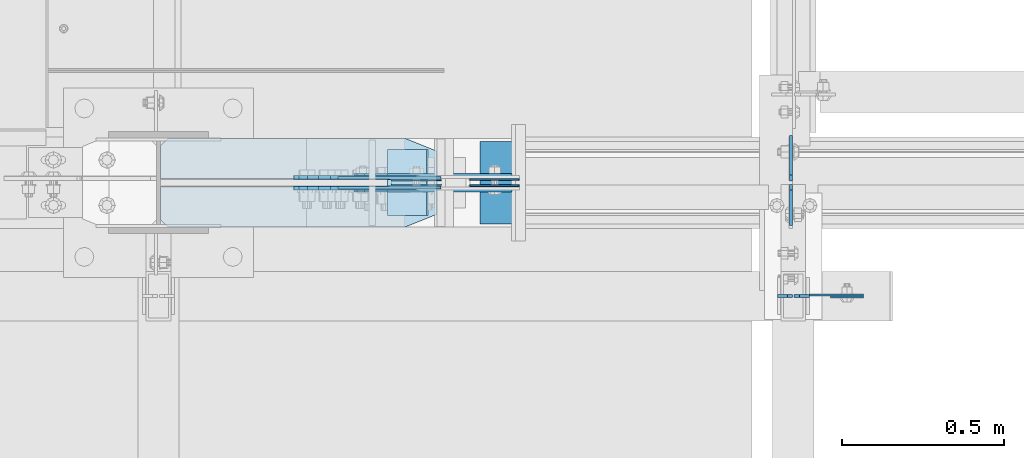
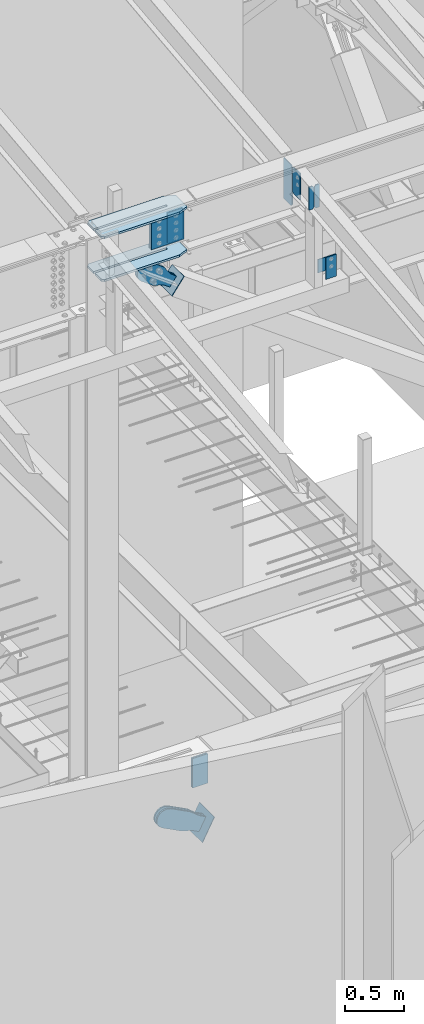
# One storey, part 998 of 1179: 20 plates, 14 elements without a shape of their own.
"""IFC2X3 building model written with IfcOpenShell, lengths in millimetres."""

from ifc_helpers import new_model, si_unit, frame, origin_with_axes, place, context, subcontext, project, spatial, faceted_brep, material, type_object, element, aggregate, save


model = new_model("IFC2X3")

# Units and contexts
model_context = context("Model", 3, precision=1e-05, world=origin_with_axes())
body_context = subcontext(model_context, "Body", "Model", "MODEL_VIEW")
ifc_project = project(units=[si_unit("LENGTHUNIT", "METRE", prefix="MILLI"), si_unit("AREAUNIT", "SQUARE_METRE"), si_unit("VOLUMEUNIT", "CUBIC_METRE"), si_unit("MASSUNIT", "GRAM", prefix="KILO"), si_unit("TIMEUNIT", "SECOND"), si_unit("PLANEANGLEUNIT", "RADIAN"), si_unit("SOLIDANGLEUNIT", "STERADIAN"), si_unit("THERMODYNAMICTEMPERATUREUNIT", "DEGREE_CELSIUS"), si_unit("LUMINOUSINTENSITYUNIT", "LUMEN")], contexts=[model_context])

# Site, building, storey
site_placement = place(None, origin_with_axes())
site = spatial("IfcSite", under=ifc_project, at=site_placement, CompositionType="ELEMENT")
building_placement = place(site_placement, origin_with_axes())
building = spatial("IfcBuilding", under=site, at=building_placement, Name="Undefined", CompositionType="ELEMENT")
storey_placement = place(building_placement, origin_with_axes())
storey = spatial("IfcBuildingStorey", under=building, at=storey_placement, Name="Undefined", CompositionType="ELEMENT", Elevation=0.0)

# Assembly, plate
assembly_1_placement = place(storey_placement, origin_with_axes())
assembly_1 = element("IfcElementAssembly", 1, at=assembly_1_placement, inside=storey, Name="BEAM", AssemblyPlace="NOTDEFINED", PredefinedType="RIGID_FRAME")
ifc_material_1 = material(Name="STEEL/A36")
plate_type_1 = type_object("IfcPlateType", PredefinedType="NOTDEFINED")
plate_1_placement = place(assembly_1_placement, frame((18407.8557500839, 5430.05308465637, 9531.6412842795), z_axis=(0.0, 0.0, 1.0), x_axis=(0.0, -1.0, 0.0)))
plate_1 = element("IfcPlate", 2, at=plate_1_placement, type_object=plate_type_1, material=ifc_material_1, Name="PLATE", context=body_context, shape_type="Brep", body=[
    faceted_brep([(-1.81898940354586e-12, -4.76249999999345, 17.4624996185303), (0.0, -4.76250000000073, 257.17500038147), (0.0, 4.76250000000073, 257.17500038147), (1.81898940354586e-12, 4.76250000000073, 17.4624996185303), (17.4624996185303, -4.76250000000073, 274.637500000001), (17.4624996185303, 4.76250000000073, 274.637500000001), (127.0, -4.76250000000073, 274.637500000001), (127.0, 4.76250000000073, 274.637500000001), (127.0, -4.76250000000073, 0.0), (127.0, 4.76250000000073, 0.0), (17.4624996185157, -4.76250000000073, 0.0), (17.4624996185212, 4.76249999999345, 0.0)], [[[0, 1, 2, 3]], [[1, 4, 5, 2]], [[4, 6, 7, 5]], [[6, 8, 9, 7]], [[8, 10, 11, 9]], [[10, 0, 3, 11]], [[5, 7, 9, 11, 3, 2]], [[10, 8, 6, 4, 1, 0]]]),
])

assembly_2_placement = place(storey_placement, origin_with_axes())
assembly_2 = element("IfcElementAssembly", 3, at=assembly_2_placement, inside=storey, Name="COLUMN", AssemblyPlace="NOTDEFINED", PredefinedType="RIGID_FRAME")
plate_type_2 = type_object("IfcPlateType", PredefinedType="NOTDEFINED")
plate_2_placement = place(assembly_2_placement, frame((18630.9, 5089.525, 9029.7), z_axis=(-1.0, 0.0, 0.0), x_axis=(0.0, 0.0, -1.0)))
plate_2 = element("IfcPlate", 4, at=plate_2_placement, type_object=plate_type_2, material=ifc_material_1, Name="PLATE", context=body_context, shape_type="Brep", body=[
    faceted_brep([(0.0, -3.17500000000109, 0.0), (0.0, -3.17500000000018, 177.800000000003), (0.0, 3.17500000000018, 177.800000000003), (0.0, 3.17500000000109, 7.27595761418343e-12), (139.699996948242, -3.17500000000018, 177.800000000003), (139.699996948242, 3.17500000000018, 177.800000000003), (139.699996948242, -3.17500000000018, 0.0), (139.699996948242, 3.17500000000018, 0.0)], [[[0, 1, 2, 3]], [[1, 4, 5, 2]], [[4, 6, 7, 5]], [[6, 0, 3, 7]], [[5, 7, 3, 2]], [[6, 4, 1, 0]]]),
])
aggregate(assembly_2, [plate_2])

assembly_3_placement = place(storey_placement, origin_with_axes())
assembly_3 = element("IfcElementAssembly", 5, at=assembly_3_placement, inside=storey, Name="BEAM", AssemblyPlace="NOTDEFINED", PredefinedType="RIGID_FRAME")
plate_type_3 = type_object("IfcPlateType", PredefinedType="NOTDEFINED")
plate_3_placement = place(assembly_3_placement, frame((18630.9, 5083.175, 9029.7), z_axis=(-1.0, 0.0, 0.0), x_axis=(0.0, 0.0, -1.0)))
plate_3 = element("IfcPlate", 6, at=plate_3_placement, type_object=plate_type_3, material=ifc_material_1, Name="PLATE", context=body_context, shape_type="Brep", body=[
    faceted_brep([(0.0, -3.17500000000109, 0.0), (0.0, -3.17500000000018, 101.599999999999), (0.0, 3.17500000000018, 101.599999999999), (0.0, 3.17500000000109, 7.27595761418343e-12), (228.6, -3.17500000000018, 101.600000000002), (228.6, 3.17500000000018, 101.600000000002), (228.6, -3.17500000000018, 0.0), (228.6, 3.17500000000018, 0.0)], [[[0, 1, 2, 3]], [[1, 4, 5, 2]], [[4, 6, 7, 5]], [[6, 0, 3, 7]], [[5, 7, 3, 2]], [[6, 4, 1, 0]]]),
])
aggregate(assembly_3, [plate_3])

# Assembly, plates
assembly_4_placement = place(storey_placement, origin_with_axes())
assembly_4 = element("IfcElementAssembly", 7, at=assembly_4_placement, inside=storey, Name="COLUMN", AssemblyPlace="NOTDEFINED", PredefinedType="RIGID_FRAME")
ifc_material_2 = material(Name="STEEL/A572-GR.50")
plate_type_4 = type_object("IfcPlateType", PredefinedType="NOTDEFINED")
plate_4_placement = place(assembly_4_placement, frame((17317.4400137532, 5298.77294084992, 9371.30378424801), z_axis=(0.0, 1.0, 0.0), x_axis=(-1.0, 0.0, 0.0)))
plate_4 = element("IfcPlate", 8, at=plate_4_placement, type_object=plate_type_4, material=ifc_material_2, Name="PLATE", context=body_context, shape_type="Brep", body=[
    faceted_brep([(7.59864633437246e-08, -11.1124999999993, 39.6875), (4.47358615929261e-07, -11.1124999999993, 233.664559150106), (4.47358615929261e-07, 11.1124999999993, 233.664559150106), (7.59864633437246e-08, 11.1124999999993, 39.6875), (98.4250035750956, -11.1124999999993, 273.352058948923), (98.4250035750956, 11.1124999999993, 273.352058948923), (829.665013927734, -11.1124999999993, 273.352057454256), (829.665013927734, 11.1124999999993, 273.352057454256), (851.889731159226, -11.1124999999993, 251.127057029163), (851.889731159226, 11.1124999999993, 251.127057029163), (851.888416532773, -11.1124999999993, 147.939433912853), (851.888416532773, 11.1124999999993, 147.939433912853), (150.812500248834, -11.1124999999993, 147.939421432724), (150.812500248834, 11.1124999999993, 147.939421432724), (146.559957742298, -11.1124999999993, 147.093543911433), (146.559957742298, 11.1124999999993, 147.093543911433), (142.954817692145, -11.1124999999993, 144.684686968872), (142.954817692145, 11.1124999999993, 144.684686968872), (140.545922681831, -11.1124999999993, 141.079572354859), (140.545922681831, 11.1124999999993, 141.079572354859), (139.700000260313, -11.1124999999993, 136.827394565982), (139.700000260313, 11.1124999999993, 136.827394565982), (140.545918766416, -11.1124999999993, 132.57463537618), (140.545918766416, 11.1124999999993, 132.57463537618), (142.95496943955, -11.1124999999993, 128.969359561528), (142.95496943955, 11.1124999999993, 128.969359561528), (146.560363730703, -11.1124999999993, 126.560486204381), (146.560363730703, 11.1124999999993, 126.560486204381), (150.81316451895, -11.1124999999993, 125.714776856612), (150.81316451895, 11.1124999999993, 125.714776856612), (851.893891681961, -11.1124999999993, 125.75667252622), (851.893891681961, 11.1124999999993, 125.75667252622), (851.918629496609, -11.1124999999993, 22.2249997467889), (851.918629496609, 11.1124999999993, 22.2249997467889), (829.698939547292, -11.1124999999993, -2.38287611864507e-10), (829.698939547292, 11.1124999999993, -2.38287611864507e-10), (98.4250030517578, -11.1124999999993, -2.81943357549608e-11), (98.4250030517578, 11.1124999999993, -2.81943357549608e-11)], [[[0, 1, 2, 3]], [[1, 4, 5, 2]], [[4, 6, 7, 5]], [[6, 8, 9, 7]], [[8, 10, 11, 9]], [[10, 12, 13, 11]], [[12, 14, 15, 13]], [[14, 16, 17, 15]], [[16, 18, 19, 17]], [[18, 20, 21, 19]], [[20, 22, 23, 21]], [[22, 24, 25, 23]], [[24, 26, 27, 25]], [[26, 28, 29, 27]], [[28, 30, 31, 29]], [[30, 32, 33, 31]], [[32, 34, 35, 33]], [[34, 36, 37, 35]], [[36, 0, 3, 37]], [[5, 7, 9, 11, 13, 15, 17, 19, 21, 23, 25, 27, 29, 31, 33, 35, 37, 3, 2]], [[36, 34, 32, 30, 28, 26, 24, 22, 20, 18, 16, 14, 12, 10, 8, 6, 4, 1, 0]]]),
])
plate_5_placement = place(assembly_4_placement, frame((17317.4400137528, 5298.77294084992, 9815.80378427207), z_axis=(0.0, 1.0, 0.0), x_axis=(-1.0, 0.0, 0.0)))
plate_5 = element("IfcPlate", 9, at=plate_5_placement, type_object=plate_type_4, material=ifc_material_2, Name="PLATE", context=body_context, shape_type="Brep", body=[
    faceted_brep([(7.59864633437246e-08, -11.1124999999993, 39.6875), (4.47358615929261e-07, -11.1124999999993, 233.664559150106), (4.47358615929261e-07, 11.1124999999993, 233.664559150106), (7.59864633437246e-08, 11.1124999999993, 39.6875), (98.4250035750956, -11.1124999999993, 273.352058948923), (98.4250035750956, 11.1124999999993, 273.352058948923), (829.665013927734, -11.1124999999993, 273.352057454256), (829.665013927734, 11.1124999999993, 273.352057454256), (851.889731159226, -11.1124999999993, 251.127057029163), (851.889731159226, 11.1124999999993, 251.127057029163), (851.888416532773, -11.1124999999993, 147.939433912853), (851.888416532773, 11.1124999999993, 147.939433912853), (150.812500248834, -11.1124999999993, 147.939421432724), (150.812500248834, 11.1124999999993, 147.939421432724), (146.559957742298, -11.1124999999993, 147.093543911433), (146.559957742298, 11.1124999999993, 147.093543911433), (142.954817692145, -11.1124999999993, 144.684686968872), (142.954817692145, 11.1124999999993, 144.684686968872), (140.545922681831, -11.1124999999993, 141.079572354859), (140.545922681831, 11.1124999999993, 141.079572354859), (139.700000260313, -11.1124999999993, 136.827394565982), (139.700000260313, 11.1124999999993, 136.827394565982), (140.545918766416, -11.1124999999993, 132.57463537618), (140.545918766416, 11.1124999999993, 132.57463537618), (142.95496943955, -11.1124999999993, 128.969359561528), (142.95496943955, 11.1124999999993, 128.969359561528), (146.560363730703, -11.1124999999993, 126.560486204381), (146.560363730703, 11.1124999999993, 126.560486204381), (150.81316451895, -11.1124999999993, 125.714776856612), (150.81316451895, 11.1124999999993, 125.714776856612), (851.893891681961, -11.1124999999993, 125.75667252622), (851.893891681961, 11.1124999999993, 125.75667252622), (851.918629496609, -11.1124999999993, 22.2249997467889), (851.918629496609, 11.1124999999993, 22.2249997467889), (829.698939547292, -11.1124999999993, -2.38287611864507e-10), (829.698939547292, 11.1124999999993, -2.38287611864507e-10), (98.4250030517578, -11.1124999999993, -2.81943357549608e-11), (98.4250030517578, 11.1124999999993, -2.81943357549608e-11)], [[[0, 1, 2, 3]], [[1, 4, 5, 2]], [[4, 6, 7, 5]], [[6, 8, 9, 7]], [[8, 10, 11, 9]], [[10, 12, 13, 11]], [[12, 14, 15, 13]], [[14, 16, 17, 15]], [[16, 18, 19, 17]], [[18, 20, 21, 19]], [[20, 22, 23, 21]], [[22, 24, 25, 23]], [[24, 26, 27, 25]], [[26, 28, 29, 27]], [[28, 30, 31, 29]], [[30, 32, 33, 31]], [[32, 34, 35, 33]], [[34, 36, 37, 35]], [[36, 0, 3, 37]], [[5, 7, 9, 11, 13, 15, 17, 19, 21, 23, 25, 27, 29, 31, 33, 35, 37, 3, 2]], [[36, 34, 32, 30, 28, 26, 24, 22, 20, 18, 16, 14, 12, 10, 8, 6, 4, 1, 0]]]),
])
aggregate(assembly_4, [plate_4, plate_5])

# Assembly, plate
assembly_5_placement = place(storey_placement, origin_with_axes())
assembly_5 = element("IfcElementAssembly", 10, at=assembly_5_placement, inside=storey, Name="Plate", AssemblyPlace="NOTDEFINED", PredefinedType="RIGID_FRAME")
plate_type_5 = type_object("IfcPlateType", PredefinedType="NOTDEFINED")
plate_6_placement = place(assembly_5_placement, frame((17167.4543285345, 5334.0, 8950.88232708746), z_axis=(0.589511681969932, 0.0, 0.807759850958799), x_axis=(0.0, 1.0, 0.0)))
plate_6 = element("IfcPlate", 11, at=plate_6_placement, type_object=plate_type_5, material=ifc_material_1, Name="Plate", context=body_context, shape_type="Brep", body=[
    faceted_brep([(0.0, -3.17500000000109, 0.0), (0.0, -3.17500000000291, 203.200000000368), (0.0, 3.17499999998836, 203.200000000361), (0.0, 3.17500000000109, 7.27595761418343e-12), (203.199999999997, -3.17500000000291, 203.200000000368), (203.199999999997, 3.17499999998836, 203.200000000361), (203.199999999997, -3.17499999999927, 3.63797880709171e-12), (203.199999999997, 3.17499999999382, -3.63797880709171e-12)], [[[0, 1, 2, 3]], [[1, 4, 5, 2]], [[4, 6, 7, 5]], [[6, 0, 3, 7]], [[5, 7, 3, 2]], [[6, 4, 1, 0]]]),
])
aggregate(assembly_5, [plate_6])

# Plate
plate_type_6 = type_object("IfcPlateType", PredefinedType="NOTDEFINED")
plate_7_placement = place(assembly_1_placement, frame((18407.8557500839, 5441.16558465636, 9380.8287842795), z_axis=(0.0, 0.0, 1.0), x_axis=(0.0, 1.0, 0.0)))
plate_7 = element("IfcPlate", 12, at=plate_7_placement, type_object=plate_type_6, material=ifc_material_1, Name="PLATE", context=body_context, shape_type="Brep", body=[
    faceted_brep([(-1.81898940354586e-12, -4.76249999999345, 17.4624996185303), (0.0, -4.76250000000073, 407.98750038147), (0.0, 4.76250000000073, 407.98750038147), (1.81898940354586e-12, 4.76250000000073, 17.4624996185303), (17.4624996185303, -4.76250000000073, 425.450000000001), (17.4624996185303, 4.76250000000073, 425.450000000001), (139.699999999997, -4.76250000000073, 425.450000000001), (139.699999999997, 4.76250000000073, 425.450000000001), (139.7, -4.76249999999982, 0.0), (139.7, 4.76249999999982, 0.0), (17.4624996185157, -4.76250000000073, 0.0), (17.4624996185212, 4.76249999999345, 0.0)], [[[0, 1, 2, 3]], [[1, 4, 5, 2]], [[4, 6, 7, 5]], [[6, 8, 9, 7]], [[8, 10, 11, 9]], [[10, 0, 3, 11]], [[5, 7, 9, 11, 3, 2]], [[10, 8, 6, 4, 1, 0]]]),
])

plate_type_7 = type_object("IfcPlateType", PredefinedType="NOTDEFINED")
plate_8_placement = place(assembly_1_placement, frame((17330.1399914983, 5428.46558422337, 9752.30413387428), z_axis=(-4.72937244921922e-14, -1.59139999977924e-05, -0.999999999873372), x_axis=(-1.0, 0.0, 0.0)))
plate_8 = element("IfcPlate", 13, at=plate_8_placement, type_object=plate_type_7, material=ifc_material_2, Name="PLATE", context=body_context, shape_type="Brep", body=[
    faceted_brep([(3.63797880709171e-12, -1.58750000000055, 1.81898940354586e-12), (1.14960130304098e-09, -1.58749999998781, 317.499991883238), (1.1423253454268e-09, 1.58750000001328, 317.499991883236), (-3.63797880709171e-12, 1.58750000000055, 0.0), (152.400647503087, -1.58749999992506, 317.499974488092), (152.40064750308, 1.58750000007603, 317.49997448809), (152.400665095942, -1.58749999993688, -1.4915713109076e-10), (152.400665095935, 1.58750000006421, -1.50976120494306e-10)], [[[0, 1, 2, 3]], [[1, 4, 5, 2]], [[4, 6, 7, 5]], [[6, 0, 3, 7]], [[5, 7, 3, 2]], [[6, 4, 1, 0]]]),
])

plate_9_placement = place(assembly_1_placement, frame((17330.1399915404, 5442.75308423117, 9752.30388123034), z_axis=(-4.72937244921922e-14, -1.59139999977924e-05, -0.999999999873372), x_axis=(-1.0, 0.0, 0.0)))
plate_9 = element("IfcPlate", 14, at=plate_9_placement, type_object=plate_type_7, material=ifc_material_2, Name="PLATE", context=body_context, shape_type="Brep", body=[
    faceted_brep([(3.63797880709171e-12, -1.58750000000055, 1.81898940354586e-12), (1.14960130304098e-09, -1.58749999998781, 317.499991883238), (1.1423253454268e-09, 1.58750000001328, 317.499991883236), (-3.63797880709171e-12, 1.58750000000055, 0.0), (152.400647503087, -1.58749999992506, 317.499974488092), (152.40064750308, 1.58750000007603, 317.49997448809), (152.400665095942, -1.58749999993688, -1.4915713109076e-10), (152.400665095935, 1.58750000006421, -1.50976120494306e-10)], [[[0, 1, 2, 3]], [[1, 4, 5, 2]], [[4, 6, 7, 5]], [[6, 0, 3, 7]], [[5, 7, 3, 2]], [[6, 4, 1, 0]]]),
])

aggregate(assembly_1, [plate_8, plate_9, plate_7, plate_1])

# Assembly, plate
assembly_6_placement = place(storey_placement, origin_with_axes())
assembly_6 = element("IfcElementAssembly", 15, at=assembly_6_placement, inside=storey, Name="PLATE", AssemblyPlace="NOTDEFINED", PredefinedType="RIGID_FRAME")
plate_type_8 = type_object("IfcPlateType", PredefinedType="NOTDEFINED")
plate_10_placement = place(assembly_6_placement, frame((17330.139978687, 5421.31237496002, 9752.30378013071), z_axis=(-4.72937244921922e-14, -1.59139999977924e-05, -0.999999999873372), x_axis=(-1.0, 0.0, 0.0)))
plate_10 = element("IfcPlate", 16, at=plate_10_placement, type_object=plate_type_8, material=ifc_material_2, Name="PLATE", context=body_context, shape_type="Brep", body=[
    faceted_brep([(0.0, -4.76249999999709, 0.0), (8.00355337560177e-11, -4.7624999999889, 317.49999188591), (6.91215973347425e-11, 4.76250000001255, 317.49999188591), (0.0, 4.76249999999709, 0.0), (317.499973063801, -4.76249999985339, 317.499974491409), (317.49997306379, 4.76250000014807, 317.499974491409), (317.499990657736, -4.76249999986703, 5.00222085975111e-10), (317.499990657721, 4.76250000013533, 5.00222085975111e-10)], [[[0, 1, 2, 3]], [[1, 4, 5, 2]], [[4, 6, 7, 5]], [[6, 0, 3, 7]], [[5, 7, 3, 2]], [[6, 4, 1, 0]]]),
])
aggregate(assembly_6, [plate_10])

assembly_7_placement = place(storey_placement, origin_with_axes())
assembly_7 = element("IfcElementAssembly", 17, at=assembly_7_placement, inside=storey, Name="PLATE", AssemblyPlace="NOTDEFINED", PredefinedType="RIGID_FRAME")
plate_11_placement = place(assembly_7_placement, frame((17330.1399915401, 5449.88795228989, 9752.3037801575), z_axis=(-4.72937244921922e-14, -1.59139999977924e-05, -0.999999999873372), x_axis=(-1.0, 0.0, 0.0)))
plate_11 = element("IfcPlate", 18, at=plate_11_placement, type_object=plate_type_8, material=ifc_material_2, Name="PLATE", context=body_context, shape_type="Brep", body=[
    faceted_brep([(0.0, -4.76249999999709, 0.0), (8.00355337560177e-11, -4.7624999999889, 317.49999188591), (6.91215973347425e-11, 4.76250000001255, 317.49999188591), (0.0, 4.76249999999709, 0.0), (317.499973063801, -4.76249999985339, 317.499974491409), (317.49997306379, 4.76250000014807, 317.499974491409), (317.499990657736, -4.76249999986703, 5.00222085975111e-10), (317.499990657721, 4.76250000013533, 5.00222085975111e-10)], [[[0, 1, 2, 3]], [[1, 4, 5, 2]], [[4, 6, 7, 5]], [[6, 0, 3, 7]], [[5, 7, 3, 2]], [[6, 4, 1, 0]]]),
])
aggregate(assembly_7, [plate_11])

# Assembly, plates
assembly_8_placement = place(storey_placement, origin_with_axes())
assembly_8 = element("IfcElementAssembly", 19, at=assembly_8_placement, inside=storey, Name="BEAM", AssemblyPlace="NOTDEFINED", PredefinedType="RIGID_FRAME")
plate_type_9 = type_object("IfcPlateType", PredefinedType="NOTDEFINED")
plate_12_placement = place(assembly_8_placement, frame((18365.7875, 5086.35, 9814.71314162916), z_axis=(0.0, 0.0, -1.0), x_axis=(1.0, 0.0, 0.0)))
plate_12 = element("IfcPlate", 20, at=plate_12_placement, type_object=plate_type_9, material=ifc_material_1, Name="PLATE", context=body_context, shape_type="Brep", body=[
    faceted_brep([(0.0, -4.76249999999709, 0.0), (0.0, -4.76249999999982, 240.171811375247), (0.0, 4.76249999999982, 240.171811375247), (0.0, 4.76249999999709, 0.0), (30.9562500000029, -4.76249999999982, 240.171811375247), (30.9562500000029, 4.76249999999982, 240.171811375247), (46.8312500000029, -4.76249999999982, 224.296811375247), (46.8312500000029, 4.76249999999982, 224.296811375247), (46.8312500000029, -4.76249999999982, 15.875), (46.8312500000029, 4.76249999999982, 15.875), (30.9562500000029, -4.76249999999982, 0.0), (30.9562500000029, 4.76249999999982, 0.0)], [[[0, 1, 2, 3]], [[1, 4, 5, 2]], [[4, 6, 7, 5]], [[6, 8, 9, 7]], [[8, 10, 11, 9]], [[10, 0, 3, 11]], [[5, 7, 9, 11, 3, 2]], [[10, 8, 6, 4, 1, 0]]]),
])
plate_13_placement = place(assembly_8_placement, frame((18417.38125, 5086.35, 9814.71314162916), z_axis=(0.0, 0.0, -1.0), x_axis=(1.0, 0.0, 0.0)))
plate_13 = element("IfcPlate", 21, at=plate_13_placement, type_object=plate_type_9, material=ifc_material_1, Name="PLATE", context=body_context, shape_type="Brep", body=[
    faceted_brep([(-1.81898940354586e-12, -4.76249999999936, 15.875), (0.0, -4.76249999999982, 224.296811375247), (0.0, 4.76249999999982, 224.296811375247), (1.81898940354586e-12, 4.76249999999936, 15.875), (15.875, -4.76249999999982, 240.171811375247), (15.875, 4.76249999999982, 240.171811375247), (46.8312500000029, -4.76249999999982, 240.171811375247), (46.8312500000029, 4.76249999999982, 240.171811375247), (46.8312500000029, -4.76249999999982, 0.0), (46.8312500000029, 4.76249999999982, 0.0), (15.8749999999891, -4.76249999999845, 0.0), (15.8749999999945, 4.76250000000027, 0.0)], [[[0, 1, 2, 3]], [[1, 4, 5, 2]], [[4, 6, 7, 5]], [[6, 8, 9, 7]], [[8, 10, 11, 9]], [[10, 0, 3, 11]], [[5, 7, 9, 11, 3, 2]], [[10, 8, 6, 4, 1, 0]]]),
])
aggregate(assembly_8, [plate_12, plate_13])

assembly_9_placement = place(storey_placement, origin_with_axes())
assembly_9 = element("IfcElementAssembly", 22, at=assembly_9_placement, inside=storey, Name="BEAM", AssemblyPlace="NOTDEFINED", PredefinedType="RIGID_FRAME")
plate_type_10 = type_object("IfcPlateType", PredefinedType="NOTDEFINED")
plate_14_placement = place(assembly_9_placement, frame((17571.135110306, 5445.12525, 4017.9625), z_axis=(0.0, 0.0, -1.0), x_axis=(-1.0, 0.0, 0.0)))
plate_14 = element("IfcPlate", 23, at=plate_14_placement, type_object=plate_type_10, material=ifc_material_2, Name="PLATE", context=body_context, shape_type="Brep", body=[
    faceted_brep([(0.0, -2.38150000000041, 0.0), (0.0, -2.38150000000041, 304.8), (0.0, 2.38150000000041, 304.8), (0.0, 2.38150000000041, 0.0), (152.400000000001, -2.38150000000041, 304.8), (152.400000000001, 2.38150000000041, 304.8), (152.400000000001, -2.38150000000041, 0.0), (152.400000000001, 2.38150000000041, 0.0)], [[[0, 1, 2, 3]], [[1, 4, 5, 2]], [[4, 6, 7, 5]], [[6, 0, 3, 7]], [[5, 7, 3, 2]], [[6, 4, 1, 0]]]),
])
plate_15_placement = place(assembly_9_placement, frame((17571.135110306, 5426.07475, 4017.9625), z_axis=(0.0, 0.0, -1.0), x_axis=(-1.0, 0.0, 0.0)))
plate_15 = element("IfcPlate", 24, at=plate_15_placement, type_object=plate_type_10, material=ifc_material_2, Name="PLATE", context=body_context, shape_type="Brep", body=[
    faceted_brep([(0.0, -2.38150000000041, 0.0), (0.0, -2.38150000000041, 304.8), (0.0, 2.38150000000041, 304.8), (0.0, 2.38150000000041, 0.0), (152.400000000001, -2.38150000000041, 304.8), (152.400000000001, 2.38150000000041, 304.8), (152.400000000001, -2.38150000000041, 0.0), (152.400000000001, 2.38150000000041, 0.0)], [[[0, 1, 2, 3]], [[1, 4, 5, 2]], [[4, 6, 7, 5]], [[6, 0, 3, 7]], [[5, 7, 3, 2]], [[6, 4, 1, 0]]]),
])
aggregate(assembly_9, [plate_14, plate_15])

# Assembly, plate
assembly_10_placement = place(storey_placement, origin_with_axes())
assembly_10 = element("IfcElementAssembly", 25, at=assembly_10_placement, inside=storey, AssemblyPlace="NOTDEFINED", PredefinedType="RIGID_FRAME")
plate_type_11 = type_object("IfcPlateType", PredefinedType="NOTDEFINED")
plate_16_placement = place(assembly_10_placement, frame((17132.2173236481, 5451.475, 9032.93661653548), z_axis=(0.589511681969932, 0.0, 0.807759850958799), x_axis=(0.807759850958799, 0.0, -0.589511681969932)))
plate_16 = element("IfcPlate", 26, at=plate_16_placement, type_object=plate_type_11, material=ifc_material_1, context=body_context, shape_type="Brep", body=[
    faceted_brep([(0.0, -6.34999999999854, 0.0), (-101.599999999963, -6.34999999999854, -37.5700345970108), (-101.599999999963, 6.34999999999854, -37.5700345970108), (0.0, 6.34999999999854, 0.0), (-245.369242323884, -6.34999999999854, -37.5700345970945), (-245.369242323884, 6.34999999999854, -37.5700345970945), (-281.212328723803, -6.34999999999854, -30.4404014271258), (-281.212328723803, 6.34999999999854, -30.4404014271258), (-311.598630137756, -6.34999999999854, -10.1369239370142), (-311.598630137756, 6.34999999999854, -10.1369239370142), (-331.902107627997, -6.34999999999854, 20.24937747687), (-331.902107627997, 6.34999999999854, 20.24937747687), (-339.031740798124, -6.34999999999854, 56.0924669287269), (-339.031740798124, 6.34999999999854, 56.0924669287269), (-331.902107628228, -6.34999999999854, 91.9355533287926), (-331.902107628228, 6.34999999999854, 91.9355533287926), (-311.598630138099, -6.34999999999854, 122.321854742866), (-311.598630138099, 6.34999999999854, 122.321854742866), (-281.212328724136, -6.34999999999854, 142.625332233139), (-281.212328724136, 6.34999999999854, 142.625332233139), (-245.36924079839, -6.34999999999854, 149.754965403199), (-245.36924079839, 6.34999999999854, 149.754965403199), (-101.600000000685, -6.34999999999854, 149.75496540329), (-101.600000000685, 6.34999999999854, 149.75496540329), (-4.35647962149233e-10, -6.34999999999854, 112.184930806416), (-4.35647962149233e-10, 6.34999999999854, 112.184930806416), (80.0100000001657, -6.35000000000036, 112.184930806456), (80.0100000001657, 6.35000000000036, 112.184930806456), (80.0100000001621, -6.35000000000036, 0.0), (80.0100000001621, 6.35000000000036, 0.0)], [[[0, 1, 2, 3]], [[1, 4, 5, 2]], [[4, 6, 7, 5]], [[6, 8, 9, 7]], [[8, 10, 11, 9]], [[10, 12, 13, 11]], [[12, 14, 15, 13]], [[14, 16, 17, 15]], [[16, 18, 19, 17]], [[18, 20, 21, 19]], [[20, 22, 23, 21]], [[22, 24, 25, 23]], [[24, 26, 27, 25]], [[26, 28, 29, 27]], [[28, 0, 3, 29]], [[5, 7, 9, 11, 13, 15, 17, 19, 21, 23, 25, 27, 29, 3, 2]], [[28, 26, 24, 22, 20, 18, 16, 14, 12, 10, 8, 6, 4, 1, 0]]]),
])
aggregate(assembly_10, [plate_16])

assembly_11_placement = place(storey_placement, origin_with_axes())
assembly_11 = element("IfcElementAssembly", 27, at=assembly_11_placement, inside=storey, AssemblyPlace="NOTDEFINED", PredefinedType="RIGID_FRAME")
plate_17_placement = place(assembly_11_placement, frame((17132.2173236481, 5419.725, 9032.93661653548), z_axis=(0.589511681969932, 0.0, 0.807759850958799), x_axis=(0.807759850958799, 0.0, -0.589511681969932)))
plate_17 = element("IfcPlate", 28, at=plate_17_placement, type_object=plate_type_11, material=ifc_material_1, context=body_context, shape_type="Brep", body=[
    faceted_brep([(0.0, -6.34999999999854, 0.0), (-101.599999999963, -6.34999999999854, -37.5700345970108), (-101.599999999963, 6.34999999999854, -37.5700345970108), (0.0, 6.34999999999854, 0.0), (-245.369242323884, -6.34999999999854, -37.5700345970945), (-245.369242323884, 6.34999999999854, -37.5700345970945), (-281.212328723803, -6.34999999999854, -30.4404014271258), (-281.212328723803, 6.34999999999854, -30.4404014271258), (-311.598630137756, -6.34999999999854, -10.1369239370142), (-311.598630137756, 6.34999999999854, -10.1369239370142), (-331.902107627997, -6.34999999999854, 20.24937747687), (-331.902107627997, 6.34999999999854, 20.24937747687), (-339.031740798124, -6.34999999999854, 56.0924669287269), (-339.031740798124, 6.34999999999854, 56.0924669287269), (-331.902107628228, -6.34999999999854, 91.9355533287926), (-331.902107628228, 6.34999999999854, 91.9355533287926), (-311.598630138099, -6.34999999999854, 122.321854742866), (-311.598630138099, 6.34999999999854, 122.321854742866), (-281.212328724136, -6.34999999999854, 142.625332233139), (-281.212328724136, 6.34999999999854, 142.625332233139), (-245.36924079839, -6.34999999999854, 149.754965403199), (-245.36924079839, 6.34999999999854, 149.754965403199), (-101.600000000685, -6.34999999999854, 149.75496540329), (-101.600000000685, 6.34999999999854, 149.75496540329), (-4.35647962149233e-10, -6.34999999999854, 112.184930806416), (-4.35647962149233e-10, 6.34999999999854, 112.184930806416), (80.0100000001657, -6.35000000000036, 112.184930806456), (80.0100000001657, 6.35000000000036, 112.184930806456), (80.0100000001621, -6.35000000000036, 0.0), (80.0100000001621, 6.35000000000036, 0.0)], [[[0, 1, 2, 3]], [[1, 4, 5, 2]], [[4, 6, 7, 5]], [[6, 8, 9, 7]], [[8, 10, 11, 9]], [[10, 12, 13, 11]], [[12, 14, 15, 13]], [[14, 16, 17, 15]], [[16, 18, 19, 17]], [[18, 20, 21, 19]], [[20, 22, 23, 21]], [[22, 24, 25, 23]], [[24, 26, 27, 25]], [[26, 28, 29, 27]], [[28, 0, 3, 29]], [[5, 7, 9, 11, 13, 15, 17, 19, 21, 23, 25, 27, 29, 3, 2]], [[28, 26, 24, 22, 20, 18, 16, 14, 12, 10, 8, 6, 4, 1, 0]]]),
])
aggregate(assembly_11, [plate_17])

assembly_12_placement = place(storey_placement, origin_with_axes())
assembly_12 = element("IfcElementAssembly", 29, at=assembly_12_placement, inside=storey, Name="Plate", AssemblyPlace="NOTDEFINED", PredefinedType="RIGID_FRAME")
plate_type_12 = type_object("IfcPlateType", PredefinedType="NOTDEFINED")
plate_18_placement = place(assembly_12_placement, frame((17452.3393727475, 5562.6, 3205.96022703208), z_axis=(0.461369686935621, 0.0, 0.887207986876204), x_axis=(0.0, -1.0, 0.0)))
plate_18 = element("IfcPlate", 30, at=plate_18_placement, type_object=plate_type_12, material=ifc_material_1, Name="Plate", context=body_context, shape_type="Brep", body=[
    faceted_brep([(0.0, -3.17500000000109, 0.0), (0.0, -3.17499999986103, 253.99999999967), (0.0, 3.17500000013752, 253.999999999668), (0.0, 3.17500000000109, 7.27595761418343e-12), (254.0, -3.17499999986103, 253.99999999967), (254.0, 3.17500000013752, 253.999999999668), (254.0, -3.17500000000109, 9.09494701772928e-13), (254.0, 3.17499999999745, -1.36424205265939e-12)], [[[0, 1, 2, 3]], [[1, 4, 5, 2]], [[4, 6, 7, 5]], [[6, 0, 3, 7]], [[5, 7, 3, 2]], [[6, 4, 1, 0]]]),
])
aggregate(assembly_12, [plate_18])

assembly_13_placement = place(storey_placement, origin_with_axes())
assembly_13 = element("IfcElementAssembly", 31, at=assembly_13_placement, inside=storey, AssemblyPlace="NOTDEFINED", PredefinedType="RIGID_FRAME")
plate_type_13 = type_object("IfcPlateType", PredefinedType="NOTDEFINED")
plate_19_placement = place(assembly_13_placement, frame((17474.3999091052, 5456.2375, 3420.42443409184), z_axis=(-0.461369686935624, 0.0, -0.887207986876203), x_axis=(0.887207986876203, 0.0, -0.461369686935623)))
plate_19 = element("IfcPlate", 32, at=plate_19_placement, type_object=plate_type_13, material=ifc_material_1, context=body_context, shape_type="Brep", body=[
    faceted_brep([(0.0, -7.9375, 0.0), (-101.600000000497, -7.9375, -21.7975798445477), (-101.600000000497, 7.9375, -21.7975798445477), (0.0, 7.9375, 0.0), (-320.921138851689, -7.9375, -21.7975798443877), (-320.921138851689, 7.9375, -21.7975798443877), (-357.371735784433, -7.9375, -14.5471053160727), (-357.371735784433, 7.9375, -14.5471053160727), (-388.273059759649, -7.9375, 6.10049924760824), (-388.273059759649, 7.9375, 6.10049924760824), (-408.920664323319, -7.9375, 37.0018232228431), (-408.920664323319, 7.9375, 37.0018232228431), (-416.171138851623, -7.9375, 73.4524201546446), (-416.171138851623, 7.9375, 73.4524201546446), (-408.920664323337, -7.9375, 109.903017087447), (-408.920664323337, 7.9375, 109.903017087447), (-388.273059759656, -7.9375, 140.804341062707), (-388.273059759656, 7.9375, 140.804341062707), (-357.3717357844, -7.9375, 161.451945626395), (-357.3717357844, 7.9375, 161.451945626395), (-320.921138851201, -7.9375, 168.702420154674), (-320.921138851201, 7.9375, 168.702420154674), (-101.600000000592, -7.9375, 168.702420154521), (-101.600000000592, 7.9375, 168.702420154521), (-8.00355337560177e-11, -7.9375, 146.904840309817), (-8.00355337560177e-11, 7.9375, 146.904840309817), (82.5499999998137, -7.9375, 146.90484031055), (82.5499999998137, 7.9375, 146.90484031055), (82.5500000000975, -7.9375, -6.91215973347425e-11), (82.5500000000975, 7.9375, -6.91215973347425e-11)], [[[0, 1, 2, 3]], [[1, 4, 5, 2]], [[4, 6, 7, 5]], [[6, 8, 9, 7]], [[8, 10, 11, 9]], [[10, 12, 13, 11]], [[12, 14, 15, 13]], [[14, 16, 17, 15]], [[16, 18, 19, 17]], [[18, 20, 21, 19]], [[20, 22, 23, 21]], [[22, 24, 25, 23]], [[24, 26, 27, 25]], [[26, 28, 29, 27]], [[28, 0, 3, 29]], [[5, 7, 9, 11, 13, 15, 17, 19, 21, 23, 25, 27, 29, 3, 2]], [[28, 26, 24, 22, 20, 18, 16, 14, 12, 10, 8, 6, 4, 1, 0]]]),
])
aggregate(assembly_13, [plate_19])

assembly_14_placement = place(storey_placement, origin_with_axes())
assembly_14 = element("IfcElementAssembly", 33, at=assembly_14_placement, inside=storey, AssemblyPlace="NOTDEFINED", PredefinedType="RIGID_FRAME")
plate_20_placement = place(assembly_14_placement, frame((17474.3999091052, 5414.9625, 3420.42443409184), z_axis=(-0.461369686935624, 0.0, -0.887207986876203), x_axis=(0.887207986876203, 0.0, -0.461369686935623)))
plate_20 = element("IfcPlate", 34, at=plate_20_placement, type_object=plate_type_13, material=ifc_material_1, context=body_context, shape_type="Brep", body=[
    faceted_brep([(0.0, -7.9375, 0.0), (-101.600000000497, -7.9375, -21.7975798445477), (-101.600000000497, 7.9375, -21.7975798445477), (0.0, 7.9375, 0.0), (-320.921138851689, -7.9375, -21.7975798443877), (-320.921138851689, 7.9375, -21.7975798443877), (-357.371735784433, -7.9375, -14.5471053160727), (-357.371735784433, 7.9375, -14.5471053160727), (-388.273059759649, -7.9375, 6.10049924760824), (-388.273059759649, 7.9375, 6.10049924760824), (-408.920664323319, -7.9375, 37.0018232228431), (-408.920664323319, 7.9375, 37.0018232228431), (-416.171138851623, -7.9375, 73.4524201546446), (-416.171138851623, 7.9375, 73.4524201546446), (-408.920664323337, -7.9375, 109.903017087447), (-408.920664323337, 7.9375, 109.903017087447), (-388.273059759656, -7.9375, 140.804341062707), (-388.273059759656, 7.9375, 140.804341062707), (-357.3717357844, -7.9375, 161.451945626395), (-357.3717357844, 7.9375, 161.451945626395), (-320.921138851201, -7.9375, 168.702420154674), (-320.921138851201, 7.9375, 168.702420154674), (-101.600000000592, -7.9375, 168.702420154521), (-101.600000000592, 7.9375, 168.702420154521), (-8.00355337560177e-11, -7.9375, 146.904840309817), (-8.00355337560177e-11, 7.9375, 146.904840309817), (82.5499999998137, -7.9375, 146.90484031055), (82.5499999998137, 7.9375, 146.90484031055), (82.5500000000975, -7.9375, -6.91215973347425e-11), (82.5500000000975, 7.9375, -6.91215973347425e-11)], [[[0, 1, 2, 3]], [[1, 4, 5, 2]], [[4, 6, 7, 5]], [[6, 8, 9, 7]], [[8, 10, 11, 9]], [[10, 12, 13, 11]], [[12, 14, 15, 13]], [[14, 16, 17, 15]], [[16, 18, 19, 17]], [[18, 20, 21, 19]], [[20, 22, 23, 21]], [[22, 24, 25, 23]], [[24, 26, 27, 25]], [[26, 28, 29, 27]], [[28, 0, 3, 29]], [[5, 7, 9, 11, 13, 15, 17, 19, 21, 23, 25, 27, 29, 3, 2]], [[28, 26, 24, 22, 20, 18, 16, 14, 12, 10, 8, 6, 4, 1, 0]]]),
])
aggregate(assembly_14, [plate_20])

save(model, "model.ifc")
